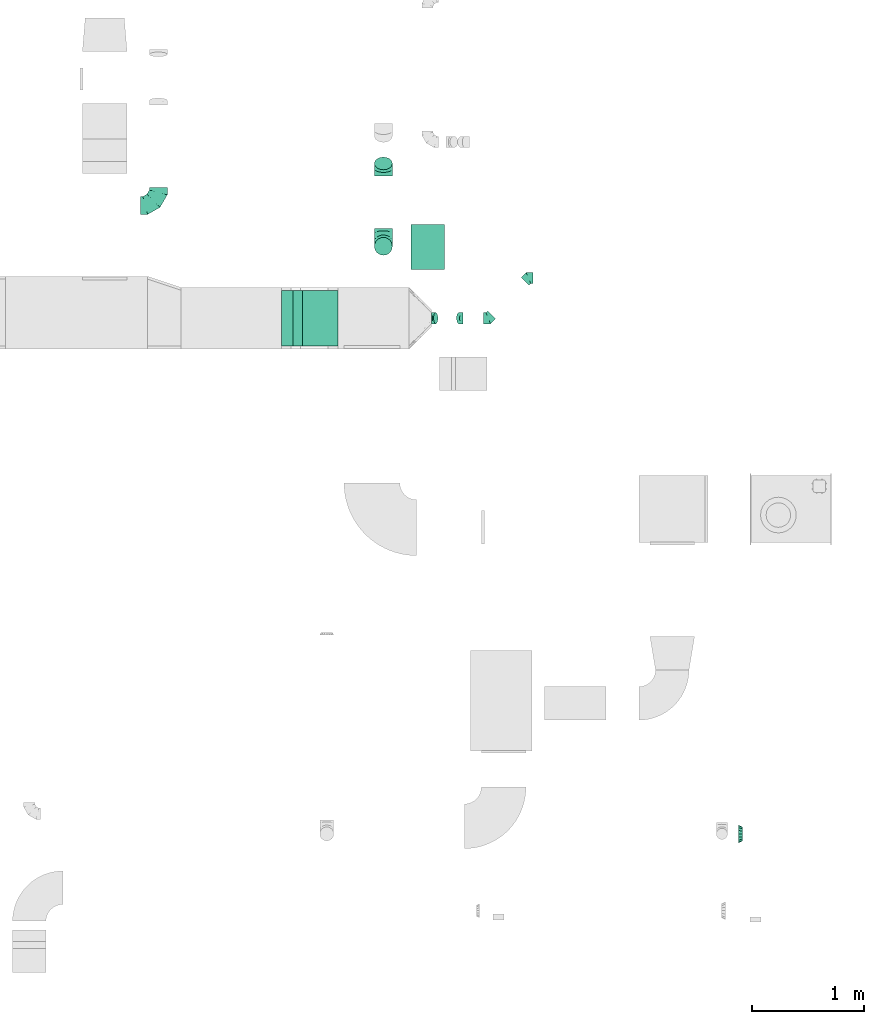
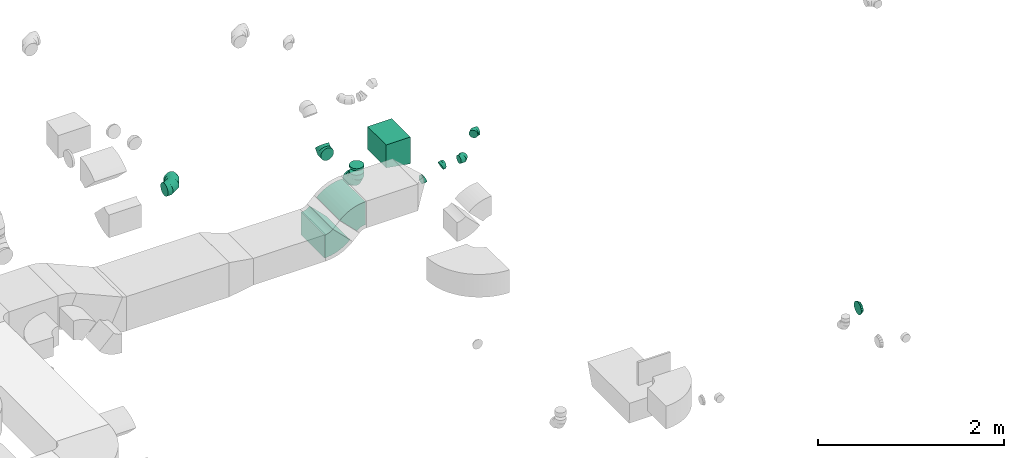
# One storey, part 14 of 44: 12 flow fittings.
"""IFC2X3 building model written with IfcOpenShell, lengths in millimetres."""

from ifc_helpers import new_model, entity, si_unit, converted_unit, derived_unit, direction, frame, frame_2d, origin, place, context, subcontext, project, spatial, polyline, circle_curve, parameter, trimmed, segment, composite_curve, outline, extrude, faceted_brep, source, transform, mapped, material, type_object, type_shapes, element, save


model = new_model("IFC2X3")

# Units and contexts
model_context = context("Model", 3, precision=0.01, world=origin(), true_north=direction((6.12303176911189e-17, 1.0)))
body_context = subcontext(model_context, "Body", "Model", "MODEL_VIEW")
ifc_project = project(units=[si_unit("LENGTHUNIT", "METRE", prefix="MILLI"), si_unit("AREAUNIT", "SQUARE_METRE"), si_unit("VOLUMEUNIT", "CUBIC_METRE"), converted_unit("PLANEANGLEUNIT", "DEGREE", entity("IfcRatioMeasure", 0.0174532925199433), si_unit("PLANEANGLEUNIT", "RADIAN"), dimensions=[0, 0, 0, 0, 0, 0, 0]), si_unit("MASSUNIT", "GRAM", prefix="KILO"), derived_unit("MASSDENSITYUNIT", [(si_unit("MASSUNIT", "GRAM", prefix="KILO"), 1), (si_unit("LENGTHUNIT", "METRE"), -3)]), derived_unit("MOMENTOFINERTIAUNIT", [(si_unit("LENGTHUNIT", "METRE"), 4)]), si_unit("TIMEUNIT", "SECOND"), si_unit("FREQUENCYUNIT", "HERTZ"), si_unit("THERMODYNAMICTEMPERATUREUNIT", "DEGREE_CELSIUS"), derived_unit("THERMALTRANSMITTANCEUNIT", [(si_unit("MASSUNIT", "GRAM", prefix="KILO"), 1), (si_unit("THERMODYNAMICTEMPERATUREUNIT", "KELVIN"), -1), (si_unit("TIMEUNIT", "SECOND"), -3)]), derived_unit("VOLUMETRICFLOWRATEUNIT", [(si_unit("LENGTHUNIT", "METRE"), 3), (si_unit("TIMEUNIT", "SECOND"), -1)]), derived_unit("MASSFLOWRATEUNIT", [(si_unit("MASSUNIT", "GRAM", prefix="KILO"), 1), (si_unit("TIMEUNIT", "SECOND"), -1)]), derived_unit("ROTATIONALFREQUENCYUNIT", [(si_unit("TIMEUNIT", "SECOND"), -1)]), si_unit("ELECTRICCURRENTUNIT", "AMPERE"), si_unit("ELECTRICVOLTAGEUNIT", "VOLT"), si_unit("POWERUNIT", "WATT"), si_unit("FORCEUNIT", "NEWTON", prefix="KILO"), si_unit("ILLUMINANCEUNIT", "LUX"), si_unit("LUMINOUSFLUXUNIT", "LUMEN"), si_unit("LUMINOUSINTENSITYUNIT", "CANDELA"), derived_unit("USERDEFINED", [(si_unit("MASSUNIT", "GRAM", prefix="KILO"), -1), (si_unit("LENGTHUNIT", "METRE"), -2), (si_unit("TIMEUNIT", "SECOND"), 3), (si_unit("LUMINOUSFLUXUNIT", "LUMEN"), 1)]), derived_unit("LINEARVELOCITYUNIT", [(si_unit("LENGTHUNIT", "METRE"), 1), (si_unit("TIMEUNIT", "SECOND"), -1)]), si_unit("PRESSUREUNIT", "PASCAL"), derived_unit("USERDEFINED", [(si_unit("LENGTHUNIT", "METRE"), -2), (si_unit("MASSUNIT", "GRAM", prefix="KILO"), 1), (si_unit("TIMEUNIT", "SECOND"), -2)]), derived_unit("LINEARFORCEUNIT", [(si_unit("MASSUNIT", "GRAM", prefix="KILO"), 1), (si_unit("LENGTHUNIT", "METRE"), 1), (si_unit("TIMEUNIT", "SECOND"), -2), (si_unit("LENGTHUNIT", "METRE"), -1)]), derived_unit("PLANARFORCEUNIT", [(si_unit("MASSUNIT", "GRAM", prefix="KILO"), 1), (si_unit("LENGTHUNIT", "METRE"), 1), (si_unit("TIMEUNIT", "SECOND"), -2), (si_unit("LENGTHUNIT", "METRE"), -2)])], contexts=[model_context])

# Site, building, storey
site_placement = place(None, origin())
site = spatial("IfcSite", under=ifc_project, at=site_placement, CompositionType="ELEMENT")
building_placement = place(site_placement, origin())
building = spatial("IfcBuilding", under=site, at=building_placement, CompositionType="ELEMENT")
storey_placement = place(building_placement, frame((0.0, 0.0, 15900.0)))
storey = spatial("IfcBuildingStorey", under=building, at=storey_placement, CompositionType="ELEMENT", Elevation=15900.0)

# Flow fittings
ifc_material = material()
duct_fitting_type_1 = type_object("IfcDuctFittingType", PredefinedType="NOTDEFINED", material=ifc_material)
shared_shape_1 = source(origin(), body_context, "Body", "SweptSolid", [
    extrude(outline(polyline([(-150.0, -162.5), (150.0, -162.5), (150.0, 137.5), (-150.0, 187.5), (-150.0, -162.5)])), frame((150.0, -200.0, 12.5), z_axis=(0.0, 1.0, 0.0), x_axis=(1.0, 0.0, 0.0)), (0.0, 0.0, 1.0), 400.0),
])
type_shapes(duct_fitting_type_1, [shared_shape_1])
flow_fitting_1_placement = place(storey_placement, frame((23836.83, 15310.0, 3275.0), z_axis=(0.0, 0.0, 1.0), x_axis=(-1.0, 0.0, 0.0)))
element("IfcFlowFitting", 1, at=flow_fitting_1_placement, inside=storey, type_object=duct_fitting_type_1, material=ifc_material, context=body_context, shape_type="MappedRepresentation", body=[
    mapped(shared_shape_1, transform((0.0, 0.0, 0.0), scale=1.0)),
])
duct_fitting_type_2 = type_object("IfcDuctFittingType", PredefinedType="NOTDEFINED", material=ifc_material)
shared_shape_2 = source(origin(), body_context, "Body", "Brep", [
    faceted_brep([(-160.0, 0.0, -80.0), (-160.0, -20.71, -77.27), (-160.0, -40.0, -69.28), (-160.0, -56.57, -56.57), (-160.0, -69.28, -40.0), (-160.0, -77.27, -20.71), (-160.0, -80.0, 0.0), (-160.0, -77.27, 20.71), (-160.0, -69.28, 40.0), (-160.0, -56.57, 56.57), (-160.0, -40.0, 69.28), (-160.0, -20.71, 77.27), (-160.0, 0.0, 80.0), (-160.0, 20.71, 77.27), (-160.0, 40.0, 69.28), (-160.0, 56.57, 56.57), (-160.0, 69.28, 40.0), (-160.0, 77.27, 20.71), (-160.0, 80.0, 0.0), (-160.0, 77.27, -20.71), (-160.0, 69.28, -40.0), (-160.0, 56.57, -56.57), (-160.0, 40.0, -69.28), (-160.0, 20.71, -77.27), (-122.68, 20.71, 77.27), (-127.85, 40.0, 69.28), (-117.13, 0.0, 80.0), (-132.29, 56.57, 56.57), (-137.83, 77.27, 20.71), (-138.56, 80.0, 0.0), (-135.69, 69.28, 40.0), (-135.69, 69.28, -40.0), (-132.29, 56.57, -56.57), (-137.83, 77.27, -20.71), (-122.68, 20.71, -77.27), (-117.13, 0.0, -80.0), (-127.85, 40.0, -69.28), (-111.58, -20.71, -77.27), (-106.41, -40.0, -69.28), (-101.97, -56.57, -56.57), (-98.56, -69.28, -40.0), (-96.42, -77.27, -20.71), (-95.69, -80.0, 0.0), (-96.42, -77.27, 20.71), (-98.56, -69.28, 40.0), (-101.97, -56.57, 56.57), (-106.41, -40.0, 69.28), (-111.58, -20.71, 77.27), (-58.03, 58.03, 77.27), (-72.15, 72.15, 69.28), (-42.87, 42.87, 80.0), (-84.28, 84.28, 56.57), (-93.59, 93.59, 40.0), (-99.44, 99.44, 20.71), (-101.44, 101.44, 0.0), (-99.44, 99.44, -20.71), (-93.59, 93.59, -40.0), (-84.28, 84.28, -56.57), (-58.03, 58.03, -77.27), (-42.87, 42.87, -80.0), (-72.15, 72.15, -69.28), (-27.71, 27.71, -77.27), (-13.59, 13.59, -69.28), (-1.46, 1.46, -56.57), (7.85, -7.85, -40.0), (13.7, -13.7, -20.71), (15.69, -15.69, 0.0), (13.7, -13.7, 20.71), (7.85, -7.85, 40.0), (-1.46, 1.46, 56.57), (-13.59, 13.59, 69.28), (-27.71, 27.71, 77.27), (-20.71, 122.68, 77.27), (-40.0, 127.85, 69.28), (0.0, 117.13, 80.0), (-56.57, 132.29, 56.57), (-69.28, 135.69, 40.0), (-77.27, 137.83, 20.71), (-80.0, 138.56, 0.0), (-77.27, 137.83, -20.71), (-69.28, 135.69, -40.0), (-56.57, 132.29, -56.57), (-20.71, 122.68, -77.27), (0.0, 117.13, -80.0), (-40.0, 127.85, -69.28), (20.71, 111.58, -77.27), (40.0, 106.41, -69.28), (56.57, 101.97, -56.57), (69.28, 98.56, -40.0), (77.27, 96.42, -20.71), (80.0, 95.69, 0.0), (77.27, 96.42, 20.71), (69.28, 98.56, 40.0), (56.57, 101.97, 56.57), (40.0, 106.41, 69.28), (20.71, 111.58, 77.27), (-20.71, 160.0, -77.27), (-40.0, 160.0, -69.28), (-56.57, 160.0, -56.57), (-69.28, 160.0, -40.0), (-77.27, 160.0, -20.71), (-80.0, 160.0, 0.0), (-77.27, 160.0, 20.71), (-69.28, 160.0, 40.0), (-56.57, 160.0, 56.57), (-40.0, 160.0, 69.28), (-20.71, 160.0, 77.27), (0.0, 160.0, 80.0), (20.71, 160.0, 77.27), (40.0, 160.0, 69.28), (56.57, 160.0, 56.57), (69.28, 160.0, 40.0), (77.27, 160.0, 20.71), (80.0, 160.0, 0.0), (77.27, 160.0, -20.71), (69.28, 160.0, -40.0), (56.57, 160.0, -56.57), (40.0, 160.0, -69.28), (20.71, 160.0, -77.27), (0.0, 160.0, -80.0)], [[[0, 1, 2, 3, 4, 5, 6, 7, 8, 9, 10, 11, 12, 13, 14, 15, 16, 17, 18, 19, 20, 21, 22, 23]], [[24, 25, 14, 13]], [[26, 24, 13, 12]], [[14, 25, 27, 15]], [[28, 29, 18, 17]], [[30, 28, 17, 16]], [[15, 27, 30, 16]], [[20, 31, 32, 21]], [[33, 31, 20, 19]], [[18, 29, 33, 19]], [[34, 35, 0, 23]], [[36, 34, 23, 22]], [[32, 36, 22, 21]], [[1, 0, 35, 37]], [[2, 1, 37, 38]], [[3, 2, 38, 39]], [[5, 4, 40, 41]], [[6, 5, 41, 42]], [[39, 40, 4, 3]], [[6, 42, 43, 7]], [[7, 43, 44, 8]], [[8, 44, 45, 9]], [[9, 45, 46, 10]], [[10, 46, 47, 11]], [[26, 12, 11, 47]], [[48, 49, 25, 24]], [[50, 48, 24, 26]], [[27, 25, 49, 51]], [[52, 53, 28, 30]], [[51, 52, 30, 27]], [[29, 28, 53, 54]], [[55, 56, 31, 33]], [[54, 55, 33, 29]], [[32, 31, 56, 57]], [[58, 59, 35, 34]], [[60, 58, 34, 36]], [[57, 60, 36, 32]], [[37, 35, 59, 61]], [[38, 37, 61, 62]], [[39, 38, 62, 63]], [[41, 40, 64, 65]], [[42, 41, 65, 66]], [[63, 64, 40, 39]], [[43, 42, 66, 67]], [[44, 43, 67, 68]], [[68, 69, 45, 44]], [[46, 45, 69, 70]], [[47, 46, 70, 71]], [[26, 47, 71, 50]], [[72, 73, 49, 48]], [[74, 72, 48, 50]], [[51, 49, 73, 75]], [[76, 77, 53, 52]], [[75, 76, 52, 51]], [[54, 53, 77, 78]], [[79, 80, 56, 55]], [[78, 79, 55, 54]], [[57, 56, 80, 81]], [[82, 83, 59, 58]], [[84, 82, 58, 60]], [[81, 84, 60, 57]], [[61, 59, 83, 85]], [[62, 61, 85, 86]], [[63, 62, 86, 87]], [[65, 64, 88, 89]], [[66, 65, 89, 90]], [[87, 88, 64, 63]], [[67, 66, 90, 91]], [[68, 67, 91, 92]], [[92, 93, 69, 68]], [[70, 69, 93, 94]], [[71, 70, 94, 95]], [[50, 71, 95, 74]], [[96, 97, 98, 99, 100, 101, 102, 103, 104, 105, 106, 107, 108, 109, 110, 111, 112, 113, 114, 115, 116, 117, 118, 119]], [[72, 74, 107, 106]], [[73, 72, 106, 105]], [[75, 73, 105, 104]], [[77, 76, 103, 102]], [[78, 77, 102, 101]], [[75, 104, 103, 76]], [[78, 101, 100, 79]], [[79, 100, 99, 80]], [[80, 99, 98, 81]], [[84, 97, 96, 82]], [[82, 96, 119, 83]], [[84, 81, 98, 97]], [[118, 117, 86, 85]], [[119, 118, 85, 83]], [[116, 87, 86, 117]], [[88, 115, 114, 89]], [[89, 114, 113, 90]], [[115, 88, 87, 116]], [[112, 111, 92, 91]], [[113, 112, 91, 90]], [[111, 110, 93, 92]], [[95, 94, 109, 108]], [[74, 95, 108, 107]], [[110, 109, 94, 93]]]),
])
type_shapes(duct_fitting_type_2, [shared_shape_2])
flow_fitting_2_placement = place(storey_placement, frame((21274.87, 15681.41, 3370.0)))
element("IfcFlowFitting", 2, at=flow_fitting_2_placement, inside=storey, type_object=duct_fitting_type_2, material=ifc_material, context=body_context, shape_type="MappedRepresentation", body=[
    mapped(shared_shape_2, transform((0.0, 0.0, 0.0), scale=1.0)),
])
flow_fitting_3_placement = place(storey_placement, frame((23289.37, 15316.15, 2910.59), z_axis=(-1.0, 0.0, 0.0), x_axis=(0.0, -1.0, 0.0)))
element("IfcFlowFitting", 3, at=flow_fitting_3_placement, inside=storey, type_object=duct_fitting_type_2, material=ifc_material, context=body_context, shape_type="MappedRepresentation", body=[
    mapped(shared_shape_2, transform((0.0, 0.0, 0.0), scale=1.0)),
])
duct_fitting_type_3 = type_object("IfcDuctFittingType", PredefinedType="NOTDEFINED", material=ifc_material)
shared_shape_3 = source(origin(), body_context, "Body", "Brep", [
    faceted_brep([(-66.27, 0.0, -80.0), (-66.27, -20.71, -77.27), (-66.27, -40.0, -69.28), (-66.27, -56.57, -56.57), (-66.27, -69.28, -40.0), (-66.27, -77.27, -20.71), (-66.27, -80.0, 0.0), (-66.27, -77.27, 20.71), (-66.27, -69.28, 40.0), (-66.27, -56.57, 56.57), (-66.27, -40.0, 69.28), (-66.27, -20.71, 77.27), (-66.27, 0.0, 80.0), (-66.27, 20.71, 77.27), (-66.27, 40.0, 69.28), (-66.27, 56.57, 56.57), (-66.27, 69.28, 40.0), (-66.27, 77.27, 20.71), (-66.27, 80.0, 0.0), (-66.27, 77.27, -20.71), (-66.27, 69.28, -40.0), (-66.27, 56.57, -56.57), (-66.27, 40.0, -69.28), (-66.27, 20.71, -77.27), (-8.58, 20.71, 77.27), (-16.57, 40.0, 69.28), (0.0, 0.0, 80.0), (-23.43, 56.57, 56.57), (-28.7, 69.28, 40.0), (-32.01, 77.27, 20.71), (-33.14, 80.0, 0.0), (-32.01, 77.27, -20.71), (-28.7, 69.28, -40.0), (-23.43, 56.57, -56.57), (-8.58, 20.71, -77.27), (0.0, 0.0, -80.0), (-16.57, 40.0, -69.28), (8.58, -20.71, -77.27), (16.57, -40.0, -69.28), (23.43, -56.57, -56.57), (28.7, -69.28, -40.0), (32.01, -77.27, -20.71), (33.14, -80.0, 0.0), (32.01, -77.27, 20.71), (28.7, -69.28, 40.0), (23.43, -56.57, 56.57), (16.57, -40.0, 69.28), (8.58, -20.71, 77.27), (46.86, 46.86, 80.0), (32.22, 61.5, 77.27), (18.58, 75.15, 69.28), (6.86, 86.86, 56.57), (-2.13, 95.85, 40.0), (-7.78, 101.5, 20.71), (-9.71, 103.43, 0.0), (-7.78, 101.5, -20.71), (-2.13, 95.85, -40.0), (6.86, 86.86, -56.57), (18.58, 75.15, -69.28), (32.22, 61.5, -77.27), (46.86, 46.86, -80.0), (61.5, 32.22, -77.27), (75.15, 18.58, -69.28), (86.86, 6.86, -56.57), (95.85, -2.13, -40.0), (101.5, -7.78, -20.71), (103.43, -9.71, 0.0), (101.5, -7.78, 20.71), (95.85, -2.13, 40.0), (86.86, 6.86, 56.57), (75.15, 18.58, 69.28), (61.5, 32.22, 77.27)], [[[0, 1, 2, 3, 4, 5, 6, 7, 8, 9, 10, 11, 12, 13, 14, 15, 16, 17, 18, 19, 20, 21, 22, 23]], [[24, 25, 14, 13]], [[26, 24, 13, 12]], [[14, 25, 27, 15]], [[28, 29, 17, 16]], [[28, 16, 15, 27]], [[30, 18, 17, 29]], [[31, 32, 20, 19]], [[30, 31, 19, 18]], [[32, 33, 21, 20]], [[34, 35, 0, 23]], [[36, 34, 23, 22]], [[33, 36, 22, 21]], [[1, 0, 35, 37]], [[2, 1, 37, 38]], [[38, 39, 3, 2]], [[5, 4, 40, 41]], [[6, 5, 41, 42]], [[39, 40, 4, 3]], [[6, 42, 43, 7]], [[7, 43, 44, 8]], [[8, 44, 45, 9]], [[9, 45, 46, 10]], [[10, 46, 47, 11]], [[26, 12, 11, 47]], [[24, 26, 48, 49]], [[25, 24, 49, 50]], [[27, 25, 50, 51]], [[29, 28, 52, 53]], [[30, 29, 53, 54]], [[51, 52, 28, 27]], [[30, 54, 55, 31]], [[31, 55, 56, 32]], [[57, 33, 32, 56]], [[36, 58, 59, 34]], [[34, 59, 60, 35]], [[58, 36, 33, 57]], [[35, 60, 61, 37]], [[37, 61, 62, 38]], [[63, 39, 38, 62]], [[40, 64, 65, 41]], [[41, 65, 66, 42]], [[64, 40, 39, 63]], [[43, 42, 66, 67]], [[44, 43, 67, 68]], [[68, 69, 45, 44]], [[47, 46, 70, 71]], [[26, 47, 71, 48]], [[69, 70, 46, 45]], [[59, 58, 57, 56, 55, 54, 53, 52, 51, 50, 49, 48, 71, 70, 69, 68, 67, 66, 65, 64, 63, 62, 61, 60]]]),
])
type_shapes(duct_fitting_type_3, [shared_shape_3])
flow_fitting_4_placement = place(storey_placement, frame((23289.37, 16011.15, 2910.59), z_axis=(-1.0, 0.0, 0.0), x_axis=(0.0, -0.707106781186529, -0.707106781186566)))
element("IfcFlowFitting", 4, at=flow_fitting_4_placement, inside=storey, type_object=duct_fitting_type_3, material=ifc_material, context=body_context, shape_type="MappedRepresentation", body=[
    mapped(shared_shape_3, transform((0.0, 0.0, 0.0), scale=1.0)),
])
duct_fitting_type_4 = type_object("IfcDuctFittingType", PredefinedType="NOTDEFINED", material=ifc_material)
shared_shape_4 = source(origin(), body_context, "Body", "Brep", [
    faceted_brep([(-41.42, 0.0, -50.0), (-41.42, -12.94, -48.3), (-41.42, -25.0, -43.3), (-41.42, -35.36, -35.36), (-41.42, -43.3, -25.0), (-41.42, -48.3, -12.94), (-41.42, -50.0, 0.0), (-41.42, -48.3, 12.94), (-41.42, -43.3, 25.0), (-41.42, -35.36, 35.36), (-41.42, -25.0, 43.3), (-41.42, -12.94, 48.3), (-41.42, 0.0, 50.0), (-41.42, 12.94, 48.3), (-41.42, 25.0, 43.3), (-41.42, 35.36, 35.36), (-41.42, 43.3, 25.0), (-41.42, 48.3, 12.94), (-41.42, 50.0, 0.0), (-41.42, 48.3, -12.94), (-41.42, 43.3, -25.0), (-41.42, 35.36, -35.36), (-41.42, 25.0, -43.3), (-41.42, 12.94, -48.3), (-5.36, 12.94, 48.3), (-10.36, 25.0, 43.3), (0.0, 0.0, 50.0), (-14.64, 35.36, 35.36), (-20.0, 48.3, 12.94), (-20.71, 50.0, 0.0), (-17.94, 43.3, 25.0), (-17.94, 43.3, -25.0), (-14.64, 35.36, -35.36), (-20.0, 48.3, -12.94), (-5.36, 12.94, -48.3), (0.0, 0.0, -50.0), (-10.36, 25.0, -43.3), (5.36, -12.94, -48.3), (10.36, -25.0, -43.3), (14.64, -35.36, -35.36), (17.94, -43.3, -25.0), (20.0, -48.3, -12.94), (20.71, -50.0, 0.0), (20.0, -48.3, 12.94), (17.94, -43.3, 25.0), (14.64, -35.36, 35.36), (10.36, -25.0, 43.3), (5.36, -12.94, 48.3), (29.29, 29.29, 50.0), (20.14, 38.44, 48.3), (11.61, 46.97, 43.3), (4.29, 54.29, 35.36), (-1.33, 59.91, 25.0), (-4.86, 63.44, 12.94), (-6.07, 64.64, 0.0), (-4.86, 63.44, -12.94), (-1.33, 59.91, -25.0), (4.29, 54.29, -35.36), (11.61, 46.97, -43.3), (20.14, 38.44, -48.3), (29.29, 29.29, -50.0), (38.44, 20.14, -48.3), (46.97, 11.61, -43.3), (54.29, 4.29, -35.36), (59.91, -1.33, -25.0), (63.44, -4.86, -12.94), (64.64, -6.07, 0.0), (63.44, -4.86, 12.94), (59.91, -1.33, 25.0), (54.29, 4.29, 35.36), (46.97, 11.61, 43.3), (38.44, 20.14, 48.3)], [[[0, 1, 2, 3, 4, 5, 6, 7, 8, 9, 10, 11, 12, 13, 14, 15, 16, 17, 18, 19, 20, 21, 22, 23]], [[24, 25, 14, 13]], [[26, 24, 13, 12]], [[14, 25, 27, 15]], [[28, 29, 18, 17]], [[30, 28, 17, 16]], [[16, 15, 27, 30]], [[20, 31, 32, 21]], [[33, 31, 20, 19]], [[18, 29, 33, 19]], [[34, 35, 0, 23]], [[36, 34, 23, 22]], [[32, 36, 22, 21]], [[1, 0, 35, 37]], [[2, 1, 37, 38]], [[38, 39, 3, 2]], [[5, 4, 40, 41]], [[6, 5, 41, 42]], [[39, 40, 4, 3]], [[6, 42, 43, 7]], [[7, 43, 44, 8]], [[8, 44, 45, 9]], [[9, 45, 46, 10]], [[10, 46, 47, 11]], [[26, 12, 11, 47]], [[24, 26, 48, 49]], [[25, 24, 49, 50]], [[27, 25, 50, 51]], [[28, 30, 52, 53]], [[29, 28, 53, 54]], [[27, 51, 52, 30]], [[29, 54, 55, 33]], [[33, 55, 56, 31]], [[31, 56, 57, 32]], [[36, 58, 59, 34]], [[34, 59, 60, 35]], [[36, 32, 57, 58]], [[61, 62, 38, 37]], [[60, 61, 37, 35]], [[63, 39, 38, 62]], [[40, 64, 65, 41]], [[41, 65, 66, 42]], [[64, 40, 39, 63]], [[43, 42, 66, 67]], [[44, 43, 67, 68]], [[68, 69, 45, 44]], [[47, 46, 70, 71]], [[26, 47, 71, 48]], [[69, 70, 46, 45]], [[59, 58, 57, 56, 55, 54, 53, 52, 51, 50, 49, 48, 71, 70, 69, 68, 67, 66, 65, 64, 63, 62, 61, 60]]]),
])
type_shapes(duct_fitting_type_4, [shared_shape_4])
flow_fitting_5_placement = place(storey_placement, frame((24227.52, 14672.9, 3300.5)))
element("IfcFlowFitting", 5, at=flow_fitting_5_placement, inside=storey, type_object=duct_fitting_type_4, material=ifc_material, context=body_context, shape_type="MappedRepresentation", body=[
    mapped(shared_shape_4, transform((0.0, 0.0, 0.0), scale=1.0)),
])
flow_fitting_6_placement = place(storey_placement, frame((24587.52, 15032.9, 3300.5), z_axis=(0.0, 0.0, 1.0), x_axis=(-1.0, 0.0, 0.0)))
element("IfcFlowFitting", 6, at=flow_fitting_6_placement, inside=storey, type_object=duct_fitting_type_4, material=ifc_material, context=body_context, shape_type="MappedRepresentation", body=[
    mapped(shared_shape_4, transform((0.0, 0.0, 0.0), scale=1.0)),
])
duct_fitting_type_5 = type_object("IfcDuctFittingType", PredefinedType="NOTDEFINED", material=ifc_material)
shared_shape_5 = source(origin(), body_context, "Body", "Brep", [
    faceted_brep([(35.0, 0.0, -80.0), (35.0, 12.81, -77.45), (35.0, 30.61, -73.91), (35.0, 43.59, -65.24), (35.0, 56.57, -56.57), (35.0, 65.24, -43.59), (35.0, 73.91, -30.61), (35.0, 76.96, -15.31), (35.0, 80.0, 0.0), (35.0, 77.45, 12.81), (35.0, 73.91, 30.61), (35.0, 65.24, 43.59), (35.0, 56.57, 56.57), (35.0, 43.59, 65.24), (35.0, 30.61, 73.91), (35.0, 15.31, 76.96), (35.0, 0.0, 80.0), (35.0, -12.81, 77.45), (35.0, -30.61, 73.91), (35.0, -43.59, 65.24), (35.0, -56.57, 56.57), (35.0, -65.24, 43.59), (35.0, -73.91, 30.61), (35.0, -76.96, 15.31), (35.0, -80.0, 0.0), (35.0, -77.45, -12.81), (35.0, -73.91, -30.61), (35.0, -65.24, -43.59), (35.0, -56.57, -56.57), (35.0, -43.59, -65.24), (35.0, -30.61, -73.91), (35.0, -15.31, -76.96), (0.0, -23.92, -57.74), (0.0, -34.06, -50.97), (0.0, -44.19, -44.19), (0.0, -50.97, -34.06), (0.0, -57.74, -23.92), (0.0, -60.12, -11.96), (0.0, -62.5, 0.0), (0.0, -60.12, 11.96), (0.0, -57.74, 23.92), (0.0, -50.97, 34.06), (0.0, -44.19, 44.19), (0.0, -34.06, 50.97), (0.0, -23.92, 57.74), (0.0, -11.96, 60.12), (0.0, 0.0, 62.5), (0.0, 11.96, 60.12), (0.0, 23.92, 57.74), (0.0, 34.06, 50.97), (0.0, 44.19, 44.19), (0.0, 50.97, 34.06), (0.0, 57.74, 23.92), (0.0, 60.12, 11.96), (0.0, 62.5, 0.0), (0.0, 60.12, -11.96), (0.0, 57.74, -23.92), (0.0, 50.97, -34.06), (0.0, 44.19, -44.19), (0.0, 34.06, -50.97), (0.0, 23.92, -57.74), (0.0, 11.96, -60.12), (0.0, 0.0, -62.5), (0.0, -11.96, -60.12)], [[[0, 1, 2, 3, 4, 5, 6, 7, 8, 9, 10, 11, 12, 13, 14, 15, 16, 17, 18, 19, 20, 21, 22, 23, 24, 25, 26, 27, 28, 29, 30, 31]], [[32, 33, 34, 35, 36, 37, 38, 39, 40, 41, 42, 43, 44, 45, 46, 47, 48, 49, 50, 51, 52, 53, 54, 55, 56, 57, 58, 59, 60, 61, 62, 63]], [[10, 9, 8, 54, 53, 52]], [[11, 10, 52, 51, 50, 12]], [[48, 14, 13, 12, 50, 49]], [[46, 16, 15, 14, 48, 47]], [[18, 17, 16, 46, 45, 44]], [[19, 18, 44, 43, 42, 20]], [[40, 22, 21, 20, 42, 41]], [[38, 24, 23, 22, 40, 39]], [[26, 25, 24, 38, 37, 36]], [[27, 26, 36, 35, 34, 28]], [[32, 30, 29, 28, 34, 33]], [[62, 0, 31, 30, 32, 63]], [[2, 1, 0, 62, 61, 60]], [[3, 2, 60, 59, 58, 4]], [[56, 6, 5, 4, 58, 57]], [[54, 8, 7, 6, 56, 55]]]),
])
type_shapes(duct_fitting_type_5, [shared_shape_5])
flow_fitting_7_placement = place(storey_placement, frame((26504.69, 10057.12, 3350.0), z_axis=(0.0, 0.0, 1.0), x_axis=(-1.0, 0.0, 0.0)))
element("IfcFlowFitting", 7, at=flow_fitting_7_placement, inside=storey, type_object=duct_fitting_type_5, material=ifc_material, context=body_context, shape_type="MappedRepresentation", body=[
    mapped(shared_shape_5, transform((0.0, 0.0, 0.0), scale=1.0)),
])
duct_fitting_type_6 = type_object("IfcDuctFittingType", PredefinedType="NOTDEFINED", material=ifc_material)
shared_shape_6 = source(origin(), body_context, "Body", "Brep", [
    faceted_brep([(20.0, 20.71, -77.27), (20.0, 40.0, -69.28), (20.0, 56.57, -56.57), (20.0, 69.28, -40.0), (20.0, 77.27, -20.71), (20.0, 80.0, 0.0), (20.0, 77.27, 20.71), (20.0, 69.28, 40.0), (20.0, 56.57, 56.57), (20.0, 40.0, 69.28), (20.0, 20.71, 77.27), (20.0, 0.0, 80.0), (20.0, -20.71, 77.27), (20.0, -40.0, 69.28), (20.0, -56.57, 56.57), (20.0, -69.28, 40.0), (20.0, -77.27, 20.71), (20.0, -80.0, 0.0), (20.0, -77.27, -20.71), (20.0, -69.28, -40.0), (20.0, -56.57, -56.57), (20.0, -40.0, -69.28), (20.0, -20.71, -77.27), (20.0, 0.0, -80.0), (0.0, 0.0, 80.0), (0.0, 20.71, 77.27), (-6.1, 20.71, 77.27), (-6.1, 0.0, 80.0), (0.0, 40.0, 69.28), (-6.1, 40.0, 69.28), (0.0, 56.57, 56.57), (-6.1, 56.57, 56.57), (0.0, 69.28, 40.0), (0.0, 77.27, 20.71), (-6.1, 77.27, 20.71), (-6.1, 69.28, 40.0), (0.0, 80.0, 0.0), (-6.1, 80.0, 0.0), (0.0, 77.27, -20.71), (-6.1, 77.27, -20.71), (0.0, 69.28, -40.0), (-6.1, 69.28, -40.0), (0.0, 56.57, -56.57), (-6.1, 56.57, -56.57), (0.0, 40.0, -69.28), (0.0, 20.71, -77.27), (-6.1, 20.71, -77.27), (-6.1, 40.0, -69.28), (0.0, 0.0, -80.0), (-6.1, 0.0, -80.0), (0.0, -20.71, -77.27), (-6.1, -20.71, -77.27), (0.0, -40.0, -69.28), (-6.1, -40.0, -69.28), (0.0, -56.57, -56.57), (-6.1, -56.57, -56.57), (0.0, -69.28, -40.0), (0.0, -77.27, -20.71), (-6.1, -77.27, -20.71), (-6.1, -69.28, -40.0), (0.0, -80.0, 0.0), (-6.1, -80.0, 0.0), (0.0, -77.27, 20.71), (-6.1, -77.27, 20.71), (0.0, -69.28, 40.0), (-6.1, -69.28, 40.0), (0.0, -56.57, 56.57), (-6.1, -56.57, 56.57), (0.0, -40.0, 69.28), (0.0, -20.71, 77.27), (-6.1, -20.71, 77.27), (-6.1, -40.0, 69.28)], [[[0, 1, 2, 3, 4, 5, 6, 7, 8, 9, 10, 11, 12, 13, 14, 15, 16, 17, 18, 19, 20, 21, 22, 23]], [[24, 11, 10, 25, 26, 27]], [[25, 10, 9, 28, 29, 26]], [[28, 9, 8, 30, 31, 29]], [[32, 7, 6, 33, 34, 35]], [[33, 6, 5, 36, 37, 34]], [[30, 8, 7, 32, 35, 31]], [[36, 5, 4, 38, 39, 37]], [[38, 4, 3, 40, 41, 39]], [[40, 3, 2, 42, 43, 41]], [[44, 1, 0, 45, 46, 47]], [[45, 0, 23, 48, 49, 46]], [[42, 2, 1, 44, 47, 43]], [[48, 23, 22, 50, 51, 49]], [[50, 22, 21, 52, 53, 51]], [[52, 21, 20, 54, 55, 53]], [[56, 19, 18, 57, 58, 59]], [[57, 18, 17, 60, 61, 58]], [[54, 20, 19, 56, 59, 55]], [[60, 17, 16, 62, 63, 61]], [[62, 16, 15, 64, 65, 63]], [[64, 15, 14, 66, 67, 65]], [[68, 13, 12, 69, 70, 71]], [[69, 12, 11, 24, 27, 70]], [[66, 14, 13, 68, 71, 67]], [[49, 51, 53, 55, 59, 58, 61, 63, 65, 67, 71, 70, 27, 26, 29, 31, 35, 34, 37, 39, 41, 43, 47, 46]]]),
])
type_shapes(duct_fitting_type_6, [shared_shape_6])
flow_fitting_8_placement = place(storey_placement, frame((23289.37, 15316.15, 3150.0), z_axis=(0.0, 1.0, 0.0), x_axis=(0.0, 0.0, -1.0)))
element("IfcFlowFitting", 8, at=flow_fitting_8_placement, inside=storey, type_object=duct_fitting_type_6, material=ifc_material, context=body_context, shape_type="MappedRepresentation", body=[
    mapped(shared_shape_6, transform((0.0, 0.0, 0.0), scale=1.0)),
])
duct_fitting_type_7 = type_object("IfcDuctFittingType", PredefinedType="NOTDEFINED", material=ifc_material)
shared_shape_7 = source(origin(), body_context, "Body", "Brep", [
    faceted_brep([(-19.89, 0.0, -50.0), (-19.89, -12.94, -48.3), (-19.89, -25.0, -43.3), (-19.89, -35.36, -35.36), (-19.89, -43.3, -25.0), (-19.89, -48.3, -12.94), (-19.89, -50.0, 0.0), (-19.89, -48.3, 12.94), (-19.89, -43.3, 25.0), (-19.89, -35.36, 35.36), (-19.89, -25.0, 43.3), (-19.89, -12.94, 48.3), (-19.89, 0.0, 50.0), (-19.89, 12.94, 48.3), (-19.89, 25.0, 43.3), (-19.89, 35.36, 35.36), (-19.89, 43.3, 25.0), (-19.89, 48.3, 12.94), (-19.89, 50.0, 0.0), (-19.89, 48.3, -12.94), (-19.89, 43.3, -25.0), (-19.89, 35.36, -35.36), (-19.89, 25.0, -43.3), (-19.89, 12.94, -48.3), (-2.57, 12.94, 48.3), (-4.97, 25.0, 43.3), (0.0, 0.0, 50.0), (-7.03, 35.36, 35.36), (-9.61, 48.3, 12.94), (-9.95, 50.0, 0.0), (-8.61, 43.3, 25.0), (-8.61, 43.3, -25.0), (-7.03, 35.36, -35.36), (-9.61, 48.3, -12.94), (-2.57, 12.94, -48.3), (0.0, 0.0, -50.0), (-4.97, 25.0, -43.3), (2.57, -12.94, -48.3), (4.97, -25.0, -43.3), (7.03, -35.36, -35.36), (8.61, -43.3, -25.0), (9.61, -48.3, -12.94), (9.95, -50.0, 0.0), (9.61, -48.3, 12.94), (8.61, -43.3, 25.0), (7.03, -35.36, 35.36), (4.97, -25.0, 43.3), (2.57, -12.94, 48.3), (18.38, 7.61, 50.0), (13.42, 19.57, 48.3), (8.81, 30.71, 43.3), (4.85, 40.28, 35.36), (1.81, 47.62, 25.0), (-0.11, 52.23, 12.94), (-0.76, 53.81, 0.0), (-0.11, 52.23, -12.94), (1.81, 47.62, -25.0), (4.85, 40.28, -35.36), (8.81, 30.71, -43.3), (13.42, 19.57, -48.3), (18.38, 7.61, -50.0), (23.33, -4.34, -48.3), (27.94, -15.48, -43.3), (31.91, -25.05, -35.36), (34.95, -32.39, -25.0), (36.86, -37.01, -12.94), (37.51, -38.58, 0.0), (36.86, -37.01, 12.94), (34.95, -32.39, 25.0), (31.91, -25.05, 35.36), (27.94, -15.48, 43.3), (23.33, -4.34, 48.3)], [[[0, 1, 2, 3, 4, 5, 6, 7, 8, 9, 10, 11, 12, 13, 14, 15, 16, 17, 18, 19, 20, 21, 22, 23]], [[24, 25, 14, 13]], [[26, 24, 13, 12]], [[14, 25, 27, 15]], [[28, 29, 18, 17]], [[30, 28, 17, 16]], [[15, 27, 30, 16]], [[20, 31, 32, 21]], [[33, 31, 20, 19]], [[18, 29, 33, 19]], [[34, 35, 0, 23]], [[36, 34, 23, 22]], [[32, 36, 22, 21]], [[2, 1, 37, 38]], [[3, 2, 38, 39]], [[0, 35, 37, 1]], [[5, 4, 40, 41]], [[6, 5, 41, 42]], [[39, 40, 4, 3]], [[6, 42, 43, 7]], [[7, 43, 44, 8]], [[8, 44, 45, 9]], [[10, 46, 47, 11]], [[11, 47, 26, 12]], [[9, 45, 46, 10]], [[24, 26, 48, 49]], [[25, 24, 49, 50]], [[27, 25, 50, 51]], [[28, 30, 52, 53]], [[29, 28, 53, 54]], [[27, 51, 52, 30]], [[29, 54, 55, 33]], [[33, 55, 56, 31]], [[31, 56, 57, 32]], [[36, 58, 59, 34]], [[34, 59, 60, 35]], [[36, 32, 57, 58]], [[35, 60, 61, 37]], [[37, 61, 62, 38]], [[38, 62, 63, 39]], [[40, 64, 65, 41]], [[41, 65, 66, 42]], [[39, 63, 64, 40]], [[43, 42, 66, 67]], [[44, 43, 67, 68]], [[45, 44, 68, 69]], [[47, 46, 70, 71]], [[26, 47, 71, 48]], [[69, 70, 46, 45]], [[59, 58, 57, 56, 55, 54, 53, 52, 51, 50, 49, 48, 71, 70, 69, 68, 67, 66, 65, 64, 63, 62, 61, 60]]]),
])
type_shapes(duct_fitting_type_7, [shared_shape_7])
for number, where, z_axis, x_axis in (
    (9, (23739.48, 14672.9, 3200.0), (0.0, -1.0, 0.0), (1.0, 0.0, 0.0)),
    (10, (23982.12, 14672.9, 3300.5), (0.0, 1.0, 0.0), (0.923879536840846, 0.0, 0.38268342191261)),
):
    element("IfcFlowFitting", number, at=place(storey_placement, frame(where, z_axis=z_axis, x_axis=x_axis)), inside=storey, type_object=duct_fitting_type_7, material=ifc_material, context=body_context, shape_type="MappedRepresentation", body=[
        mapped(shared_shape_7, transform((0.0, 0.0, 0.0), scale=1.0)),
    ])
duct_fitting_type_8 = type_object("IfcDuctFittingType", PredefinedType="NOTDEFINED", material=ifc_material)
shared_shape_8 = source(origin(), body_context, "Body", "SweptSolid", [
    extrude(outline(composite_curve([segment(polyline([(-193.93, -106.07), (106.07, -106.07)]), True, "CONTINUOUS"), segment(trimmed(circle_curve(frame_2d((256.07, -106.07), x_axis=(-0.707106781186553, 0.707106781186553)), 150.0), [parameter(0.0)], [parameter(45.0)], True, "PARAMETER"), False, "CONTINUOUS"), segment(polyline([(150.0, 0.0), (-62.13, 212.13)]), True, "CONTINUOUS"), segment(trimmed(circle_curve(frame_2d((256.07, -106.07), x_axis=(-0.707106781186553, 0.707106781186553)), 450.0), [parameter(0.0)], [parameter(45.0)], True, "PARAMETER"), True, "CONTINUOUS")], self_intersect=False)), frame((-18.2, 43.93, -250.0), z_axis=(0.0, 0.0, 1.0), x_axis=(-0.707106781186547, 0.707106781186548, 0.0)), (0.0, 0.0, 1.0), 500.0),
])
type_shapes(duct_fitting_type_8, [shared_shape_8])
for number, where, z_axis, x_axis in (
    (11, (22499.48, 14672.9, 2940.0), (0.0, -1.0, 0.0), (1.0, 0.0, 0.0)),
    (12, (22759.48, 14672.9, 3200.0), (0.0, 1.0, 0.0), (0.70710678118565, 0.0, 0.707106781187445)),
):
    element("IfcFlowFitting", number, at=place(storey_placement, frame(where, z_axis=z_axis, x_axis=x_axis)), inside=storey, type_object=duct_fitting_type_8, material=ifc_material, context=body_context, shape_type="MappedRepresentation", body=[
        mapped(shared_shape_8, transform((0.0, 0.0, 0.0), scale=1.0)),
    ])

save(model, "model.ifc")
